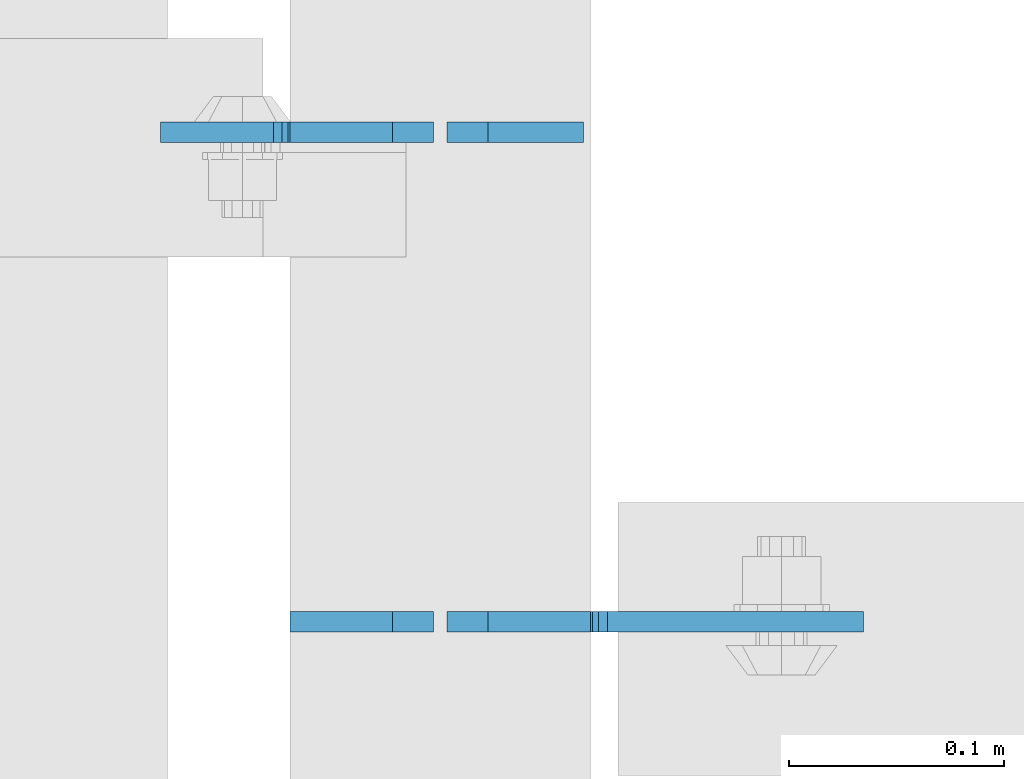
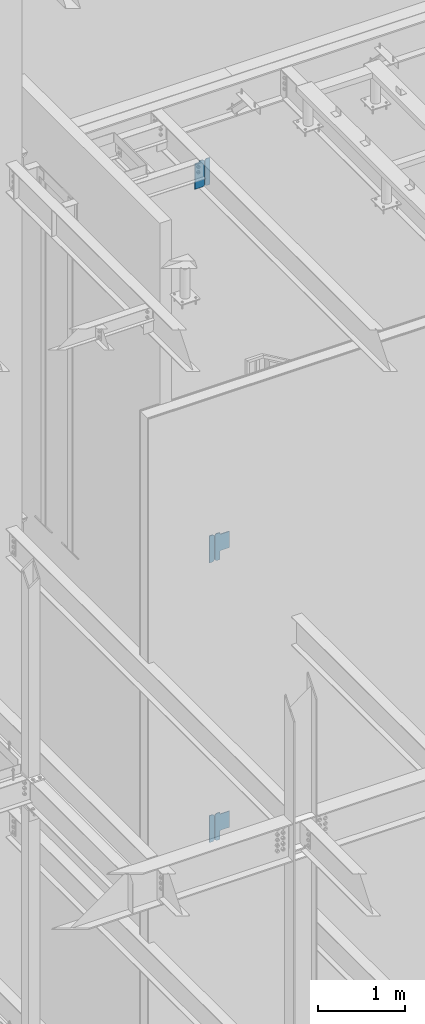
# One storey, part 1109 of 1179: 6 plates, 3 elements without a shape of their own.
"""IFC2X3 building model written with IfcOpenShell, lengths in millimetres."""

from ifc_helpers import new_model, si_unit, frame, origin_with_axes, place, context, subcontext, project, spatial, faceted_brep, material, type_object, element, aggregate, save


model = new_model("IFC2X3")

# Units and contexts
model_context = context("Model", 3, precision=1e-05, world=origin_with_axes())
body_context = subcontext(model_context, "Body", "Model", "MODEL_VIEW")
ifc_project = project(units=[si_unit("LENGTHUNIT", "METRE", prefix="MILLI"), si_unit("AREAUNIT", "SQUARE_METRE"), si_unit("VOLUMEUNIT", "CUBIC_METRE"), si_unit("MASSUNIT", "GRAM", prefix="KILO"), si_unit("TIMEUNIT", "SECOND"), si_unit("PLANEANGLEUNIT", "RADIAN"), si_unit("SOLIDANGLEUNIT", "STERADIAN"), si_unit("THERMODYNAMICTEMPERATUREUNIT", "DEGREE_CELSIUS"), si_unit("LUMINOUSINTENSITYUNIT", "LUMEN")], contexts=[model_context])

# Site, building, storey
site_placement = place(None, origin_with_axes())
site = spatial("IfcSite", under=ifc_project, at=site_placement, CompositionType="ELEMENT")
building_placement = place(site_placement, origin_with_axes())
building = spatial("IfcBuilding", under=site, at=building_placement, Name="Undefined", CompositionType="ELEMENT")
storey_placement = place(building_placement, origin_with_axes())
storey = spatial("IfcBuildingStorey", under=building, at=storey_placement, Name="Undefined", CompositionType="ELEMENT", Elevation=0.0)

# Assembly, plate
assembly_1_placement = place(storey_placement, origin_with_axes())
assembly_1 = element("IfcElementAssembly", 1, at=assembly_1_placement, inside=storey, Name="BEAM", AssemblyPlace="NOTDEFINED", PredefinedType="RIGID_FRAME")
ifc_material = material(Name="STEEL/A36")
plate_type_1 = type_object("IfcPlateType", PredefinedType="NOTDEFINED")
plate_1_placement = place(assembly_1_placement, frame((18411.825, 39986.7442499161, 12728.575), z_axis=(0.0, 0.0, 1.0), x_axis=(-1.0, 0.0, 0.0)))
plate_1 = element("IfcPlate", 2, at=plate_1_placement, type_object=plate_type_1, material=ifc_material, Name="PLATE", context=body_context, shape_type="Brep", body=[
    faceted_brep([(66.6749998164378, -4.76249999999709, 377.825), (66.6749999434469, -4.76249999999709, 371.474999553748), (66.6749999434469, 4.76249999999709, 371.474999553748), (66.6749998164378, 4.76249999999709, 377.825), (67.641729938794, -4.76249999999709, 366.614920114053), (67.641729938794, 4.76249999999709, 366.614920114053), (70.394743855788, -4.76249999999709, 362.494743732281), (70.394743855788, 4.76249999999709, 362.494743732281), (74.5149202922948, -4.76249999999709, 359.741729897201), (74.5149202922948, 4.76249999999709, 359.741729897201), (79.3749997512095, -4.76249999999709, 358.774999998475), (79.3749997512095, 4.76249999999709, 358.774999998475), (127.000000004868, -4.76249999999709, 358.774999992755), (127.0, 4.76249999999709, 358.774999992755), (0.0, -4.76249999999709, 358.775000762939), (19.0499992370605, -4.76249999999709, 377.825), (19.0499992370605, 4.76249999999709, 377.825), (0.0, 4.76249999999709, 358.775000762939), (0.0, -4.76250000000073, 19.0499992370605), (0.0, 4.76250000000073, 19.0499992370605), (19.0499992370605, -4.76250000000073, 0.0), (19.0499992370605, 4.76250000000073, 0.0), (127.0, -4.76250000000073, 0.0), (127.0, 4.76250000000073, 0.0)], [[[0, 1, 2, 3]], [[4, 5, 2, 1]], [[6, 7, 5, 4]], [[8, 9, 7, 6]], [[10, 11, 9, 8]], [[12, 13, 11, 10]], [[14, 15, 16, 17]], [[18, 14, 17, 19]], [[20, 18, 19, 21]], [[22, 20, 21, 23]], [[8, 6, 4, 1, 0, 15, 14, 18, 20, 22, 12, 10]], [[16, 15, 0, 3]], [[23, 21, 19, 17, 16, 3, 2, 5, 7, 9, 11, 13]], [[22, 23, 13, 12]]]),
])

assembly_2_placement = place(storey_placement, origin_with_axes())
assembly_2 = element("IfcElementAssembly", 3, at=assembly_2_placement, inside=storey, Name="BEAM", AssemblyPlace="NOTDEFINED", PredefinedType="RIGID_FRAME")
plate_type_2 = type_object("IfcPlateType", PredefinedType="NOTDEFINED")
plate_2_placement = place(assembly_2_placement, frame((18411.825, 39758.9379999371, 3711.575), z_axis=(0.0, 0.0, 1.0), x_axis=(-1.0, 0.0, 0.0)))
plate_2 = element("IfcPlate", 4, at=plate_2_placement, type_object=plate_type_2, material=ifc_material, Name="PLATE", context=body_context, shape_type="Brep", body=[
    faceted_brep([(0.0, -4.76250000000073, 19.0499992370605), (0.0, -4.76249999999709, 358.775000762939), (0.0, 4.76249999999709, 358.775000762939), (0.0, 4.76250000000073, 19.0499992370605), (19.0499992370605, -4.76249999999709, 377.825), (19.0499992370605, 4.76249999999709, 377.825), (66.6749386683441, -4.76249999999709, 377.825), (66.6749386683441, 4.76249999999709, 377.825), (66.6749386683441, -4.76249999999709, 0.0), (66.6749386683441, 4.76249999999709, 0.0), (19.0499992370605, -4.76250000000073, 0.0), (19.0499992370605, 4.76250000000073, 0.0)], [[[0, 1, 2, 3]], [[1, 4, 5, 2]], [[4, 6, 7, 5]], [[6, 8, 9, 7]], [[8, 10, 11, 9]], [[10, 0, 3, 11]], [[5, 7, 9, 11, 3, 2]], [[10, 8, 6, 4, 1, 0]]]),
])

assembly_3_placement = place(storey_placement, origin_with_axes())
assembly_3 = element("IfcElementAssembly", 5, at=assembly_3_placement, inside=storey, Name="BEAM", AssemblyPlace="NOTDEFINED", PredefinedType="RIGID_FRAME")
plate_3_placement = place(assembly_3_placement, frame((18411.825, 39758.9379999371, 7623.175), z_axis=(0.0, 0.0, 1.0), x_axis=(-1.0, 0.0, 0.0)))
plate_3 = element("IfcPlate", 6, at=plate_3_placement, type_object=plate_type_2, material=ifc_material, Name="PLATE", context=body_context, shape_type="Brep", body=[
    faceted_brep([(0.0, -4.76250000000073, 19.0499992370605), (0.0, -4.76249999999709, 358.775000762939), (0.0, 4.76249999999709, 358.775000762939), (0.0, 4.76250000000073, 19.0499992370605), (19.0499992370605, -4.76249999999709, 377.825), (19.0499992370605, 4.76249999999709, 377.825), (66.6749386683441, -4.76249999999709, 377.825), (66.6749386683441, 4.76249999999709, 377.825), (66.6749386683441, -4.76249999999709, 0.0), (66.6749386683441, 4.76249999999709, 0.0), (19.0499992370605, -4.76250000000073, 0.0), (19.0499992370605, 4.76250000000073, 0.0)], [[[0, 1, 2, 3]], [[1, 4, 5, 2]], [[4, 6, 7, 5]], [[6, 8, 9, 7]], [[8, 10, 11, 9]], [[10, 0, 3, 11]], [[5, 7, 9, 11, 3, 2]], [[10, 8, 6, 4, 1, 0]]]),
])

# Plate
plate_type_3 = type_object("IfcPlateType", PredefinedType="NOTDEFINED")
plate_4_placement = place(assembly_2_placement, frame((18418.175, 39758.9379999371, 3730.625), z_axis=(0.707106781186573, 0.0, 0.707106781186522), x_axis=(0.707106781186522, 0.0, -0.707106781186573)))
plate_4 = element("IfcPlate", 7, at=plate_4_placement, type_object=plate_type_3, material=ifc_material, Name="PLATE", context=body_context, shape_type="Brep", body=[
    faceted_brep([(0.0, -4.76249999999709, 0.0), (-240.221851238686, -4.76249999999709, 240.221851238675), (-240.221851238686, 4.76249999999709, 240.221851238675), (0.0, 4.76249999999709, 0.0), (-240.221851238757, -4.76249999999709, 267.162619601822), (-240.221851238757, 4.76249999999709, 267.162619601822), (-206.545890784913, -4.76249999999709, 300.838580055672), (-206.545890784913, 4.76249999999709, 300.838580055672), (-197.56563452897, -4.76249999999709, 291.858323799728), (-197.56563452897, 4.76249999999709, 291.858323799728), (-193.445458060814, -4.76249999999709, 289.105309899251), (-193.445458060814, 4.76249999999709, 289.105309899251), (-188.585378542773, -4.76249999999709, 288.138579976656), (-188.585378542773, 4.76249999999709, 288.138579976656), (-183.725299024736, -4.76249999999709, 289.105309899236), (-183.725299024736, 4.76249999999709, 289.105309899236), (-179.605122556588, -4.76249999999709, 291.858323799706), (-179.605122556588, 4.76249999999709, 291.858323799706), (-98.7828173325106, -4.76249999999709, 372.680629023791), (-98.7828173325106, 4.76249999999709, 372.680629023791), (62.8617928467938, -4.76249999999709, 211.036018844497), (62.8617928467938, 4.76249999999709, 211.036018844497), (-17.9605123772835, -4.76249999999709, 130.213713620413), (-17.9605123772835, 4.76249999999709, 130.213713620413), (-20.7135262777556, -4.76249999999709, 126.093537152266), (-20.7135262777556, 4.76249999999709, 126.093537152266), (-21.680256200334, -4.76249999999709, 121.233457634227), (-21.680256200334, 4.76249999999709, 121.233457634227), (-20.713526277741, -4.76249999999709, 116.373378116188), (-20.713526277741, 4.76249999999709, 116.373378116188), (-17.9605123772617, -4.76249999999709, 112.253201648035), (-17.9605123772617, 4.76249999999709, 112.253201648035), (60.6167288169963, -4.76249999999709, 33.675960453782), (60.6167288169963, 4.76249999999709, 33.675960453782), (26.9407683631525, -4.76249999999709, -6.18456397205591e-11), (26.9407683631525, 4.76249999999709, -6.18456397205591e-11)], [[[0, 1, 2, 3]], [[1, 4, 5, 2]], [[4, 6, 7, 5]], [[6, 8, 9, 7]], [[8, 10, 11, 9]], [[10, 12, 13, 11]], [[12, 14, 15, 13]], [[14, 16, 17, 15]], [[16, 18, 19, 17]], [[18, 20, 21, 19]], [[20, 22, 23, 21]], [[22, 24, 25, 23]], [[24, 26, 27, 25]], [[26, 28, 29, 27]], [[28, 30, 31, 29]], [[30, 32, 33, 31]], [[32, 34, 35, 33]], [[34, 0, 3, 35]], [[5, 7, 9, 11, 13, 15, 17, 19, 21, 23, 25, 27, 29, 31, 33, 35, 3, 2]], [[34, 32, 30, 28, 26, 24, 22, 20, 18, 16, 14, 12, 10, 8, 6, 4, 1, 0]]]),
])

aggregate(assembly_2, [plate_2, plate_4])

plate_5_placement = place(assembly_3_placement, frame((18418.175, 39758.9379999371, 7642.225), z_axis=(0.707106781186573, 0.0, 0.707106781186522), x_axis=(0.707106781186522, 0.0, -0.707106781186573)))
plate_5 = element("IfcPlate", 8, at=plate_5_placement, type_object=plate_type_3, material=ifc_material, Name="PLATE", context=body_context, shape_type="Brep", body=[
    faceted_brep([(0.0, -4.76249999999709, 0.0), (-240.221851238686, -4.76249999999709, 240.221851238675), (-240.221851238686, 4.76249999999709, 240.221851238675), (0.0, 4.76249999999709, 0.0), (-240.221851238757, -4.76249999999709, 267.162619601822), (-240.221851238757, 4.76249999999709, 267.162619601822), (-206.545890784913, -4.76249999999709, 300.838580055672), (-206.545890784913, 4.76249999999709, 300.838580055672), (-197.56563452897, -4.76249999999709, 291.858323799728), (-197.56563452897, 4.76249999999709, 291.858323799728), (-193.445458060814, -4.76249999999709, 289.105309899251), (-193.445458060814, 4.76249999999709, 289.105309899251), (-188.585378542773, -4.76249999999709, 288.138579976656), (-188.585378542773, 4.76249999999709, 288.138579976656), (-183.725299024736, -4.76249999999709, 289.105309899236), (-183.725299024736, 4.76249999999709, 289.105309899236), (-179.605122556588, -4.76249999999709, 291.858323799706), (-179.605122556588, 4.76249999999709, 291.858323799706), (-98.7828173325106, -4.76249999999709, 372.680629023791), (-98.7828173325106, 4.76249999999709, 372.680629023791), (62.8617928467938, -4.76249999999709, 211.036018844497), (62.8617928467938, 4.76249999999709, 211.036018844497), (-17.9605123772835, -4.76249999999709, 130.213713620413), (-17.9605123772835, 4.76249999999709, 130.213713620413), (-20.7135262777556, -4.76249999999709, 126.093537152266), (-20.7135262777556, 4.76249999999709, 126.093537152266), (-21.680256200334, -4.76249999999709, 121.233457634227), (-21.680256200334, 4.76249999999709, 121.233457634227), (-20.713526277741, -4.76249999999709, 116.373378116188), (-20.713526277741, 4.76249999999709, 116.373378116188), (-17.9605123772617, -4.76249999999709, 112.253201648035), (-17.9605123772617, 4.76249999999709, 112.253201648035), (60.6167288169963, -4.76249999999709, 33.675960453782), (60.6167288169963, 4.76249999999709, 33.675960453782), (26.9407683631525, -4.76249999999709, -6.18456397205591e-11), (26.9407683631525, 4.76249999999709, -6.18456397205591e-11)], [[[0, 1, 2, 3]], [[1, 4, 5, 2]], [[4, 6, 7, 5]], [[6, 8, 9, 7]], [[8, 10, 11, 9]], [[10, 12, 13, 11]], [[12, 14, 15, 13]], [[14, 16, 17, 15]], [[16, 18, 19, 17]], [[18, 20, 21, 19]], [[20, 22, 23, 21]], [[22, 24, 25, 23]], [[24, 26, 27, 25]], [[26, 28, 29, 27]], [[28, 30, 31, 29]], [[30, 32, 33, 31]], [[32, 34, 35, 33]], [[34, 0, 3, 35]], [[5, 7, 9, 11, 13, 15, 17, 19, 21, 23, 25, 27, 29, 31, 33, 35, 3, 2]], [[34, 32, 30, 28, 26, 24, 22, 20, 18, 16, 14, 12, 10, 8, 6, 4, 1, 0]]]),
])

aggregate(assembly_3, [plate_3, plate_5])

plate_type_4 = type_object("IfcPlateType", PredefinedType="NOTDEFINED")
plate_6_placement = place(assembly_1_placement, frame((18418.175, 39986.7442499161, 12728.575), z_axis=(0.0, 0.0, 1.0), x_axis=(1.0, 0.0, 0.0)))
plate_6 = element("IfcPlate", 9, at=plate_6_placement, type_object=plate_type_4, material=ifc_material, Name="PLATE", context=body_context, shape_type="Brep", body=[
    faceted_brep([(0.0, -4.76250000000073, 19.0499992370605), (0.0, -4.76249999999709, 358.775000762939), (0.0, 4.76249999999709, 358.775000762939), (0.0, 4.76250000000073, 19.0499992370605), (19.0499992370605, -4.76249999999709, 377.825), (19.0499992370605, 4.76249999999709, 377.825), (63.5, -4.76250000000073, 377.825012207031), (63.5, 4.76250000000073, 377.825012207031), (63.5, -4.76250000000073, 0.0), (63.5, 4.76250000000073, 0.0), (19.0499992370605, -4.76250000000073, 0.0), (19.0499992370605, 4.76250000000073, 0.0)], [[[0, 1, 2, 3]], [[1, 4, 5, 2]], [[4, 6, 7, 5]], [[6, 8, 9, 7]], [[8, 10, 11, 9]], [[10, 0, 3, 11]], [[5, 7, 9, 11, 3, 2]], [[10, 8, 6, 4, 1, 0]]]),
])

aggregate(assembly_1, [plate_6, plate_1])

save(model, "model.ifc")
